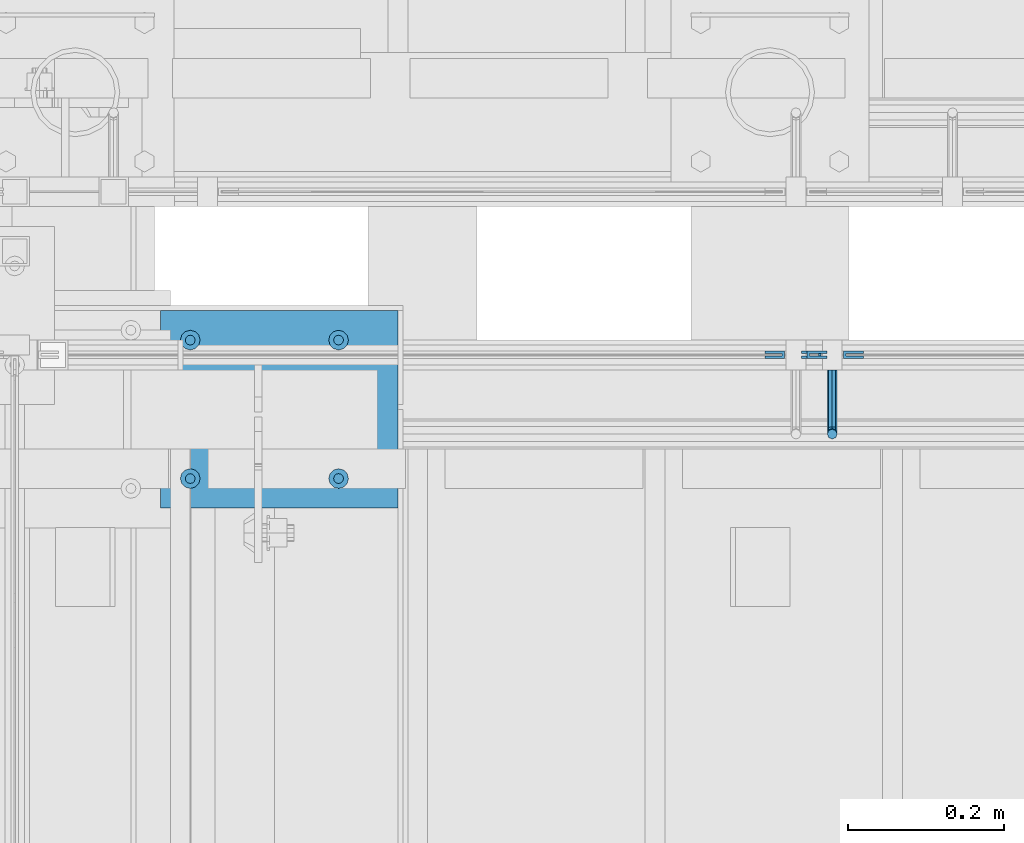
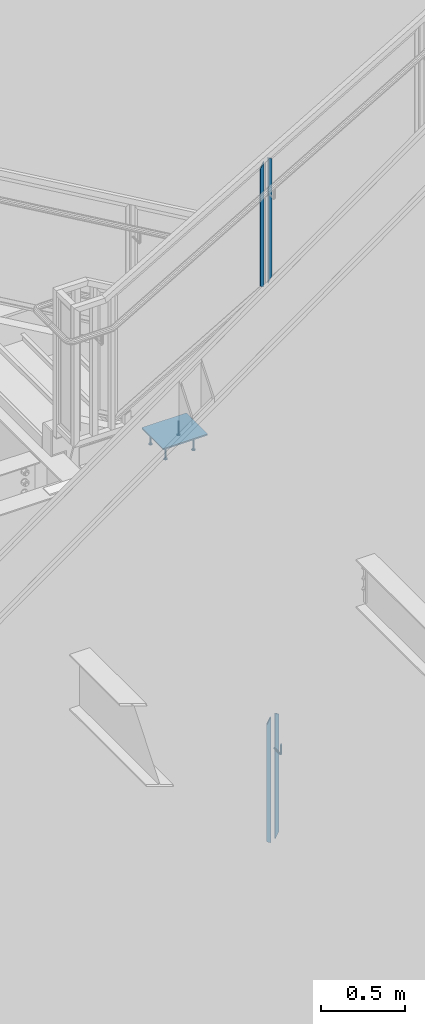
# One storey, part 912 of 1179: 10 beams, 3 elements without a shape of their own.
"""IFC2X3 building model written with IfcOpenShell, lengths in millimetres."""

from ifc_helpers import new_model, si_unit, frame, origin_with_axes, place, context, subcontext, project, spatial, faceted_brep, material, type_object, element, aggregate, save


model = new_model("IFC2X3")

# Units and contexts
model_context = context("Model", 3, precision=1e-05, world=origin_with_axes())
body_context = subcontext(model_context, "Body", "Model", "MODEL_VIEW")
ifc_project = project(units=[si_unit("LENGTHUNIT", "METRE", prefix="MILLI"), si_unit("AREAUNIT", "SQUARE_METRE"), si_unit("VOLUMEUNIT", "CUBIC_METRE"), si_unit("MASSUNIT", "GRAM", prefix="KILO"), si_unit("TIMEUNIT", "SECOND"), si_unit("PLANEANGLEUNIT", "RADIAN"), si_unit("SOLIDANGLEUNIT", "STERADIAN"), si_unit("THERMODYNAMICTEMPERATUREUNIT", "DEGREE_CELSIUS"), si_unit("LUMINOUSINTENSITYUNIT", "LUMEN")], contexts=[model_context])

# Site, building, storey
site_placement = place(None, origin_with_axes())
site = spatial("IfcSite", under=ifc_project, at=site_placement, CompositionType="ELEMENT")
building_placement = place(site_placement, origin_with_axes())
building = spatial("IfcBuilding", under=site, at=building_placement, Name="Undefined", CompositionType="ELEMENT")
storey_placement = place(building_placement, origin_with_axes())
storey = spatial("IfcBuildingStorey", under=building, at=storey_placement, Name="Undefined", CompositionType="ELEMENT", Elevation=0.0)

# Assembly, beams
assembly_1_placement = place(storey_placement, origin_with_axes())
assembly_1 = element("IfcElementAssembly", 1, at=assembly_1_placement, inside=storey, Name="GUARDRAIL", AssemblyPlace="NOTDEFINED", PredefinedType="RIGID_FRAME")
ifc_material_1 = material(Name="STEEL/BUY-OUT")
beam_type_1 = type_object("IfcBeamType", PredefinedType="NOTDEFINED")
beam_1_placement = place(assembly_1_placement, frame((20648.5331516659, 39468.4251646336, 5478.99797595162), z_axis=(0.0, 0.0, -1.0), x_axis=(-1.0, 0.0, 0.0)))
beam_1 = element("IfcBeam", 2, at=beam_1_placement, type_object=beam_type_1, material=ifc_material_1, Name="U-EDGE", context=body_context, shape_type="Brep", body=[
    faceted_brep([(0.0, 1.58750000000146, -439.43612632327), (0.0, -1.58750000000146, -439.43612632327), (0.0, -1.58750000000146, 409.802710675423), (0.0, 1.58750000000146, 409.802710675423), (22.2250000000313, 1.58750000000146, -452.201447879431), (22.2250000000313, 1.58750000000146, 448.497212762225), (22.2250000000313, 4.76249999999709, -452.201447879431), (22.2250000000313, 4.76249999999709, 448.497212762225), (6.54836185276508e-11, 4.76249999999709, -439.436126323308), (6.54836185276508e-11, 4.76249999999709, 409.802710675536), (6.54836185276508e-11, 7.9375, -439.436126323308), (6.54836185276508e-11, 7.9375, 409.802710675536), (25.4000000000342, 7.9375, -454.025), (25.4000000000342, 7.9375, 454.025), (25.4000000000342, -1.58750000000146, -454.025), (25.4000000000342, -1.58750000000146, 454.025)], [[[0, 1, 2, 3]], [[4, 0, 3, 5]], [[6, 4, 5, 7]], [[8, 6, 7, 9]], [[10, 8, 9, 11]], [[12, 10, 11, 13]], [[14, 12, 13, 15]], [[11, 9, 7, 5, 3, 2, 15, 13]], [[1, 14, 15, 2]], [[0, 4, 6, 8, 10, 12, 14, 1]]]),
])
beam_2_placement = place(assembly_1_placement, frame((20568.894845367, 39468.4251646336, 5462.17576533942), z_axis=(0.0, 0.0, -1.0), x_axis=(1.0, 0.0, 0.0)))
beam_2 = element("IfcBeam", 3, at=beam_2_placement, type_object=beam_type_1, material=ifc_material_1, Name="U-EDGE", context=body_context, shape_type="Brep", body=[
    faceted_brep([(6.54836185276508e-11, -4.76249999999709, -409.802660159926), (6.54836185276508e-11, -7.9375, -409.802660159925), (6.54836185276508e-11, -7.9375, 439.435789033928), (6.54836185276508e-11, -4.76249999999709, 439.435789033928), (22.2250000000313, -4.76249999999709, -448.497207519993), (22.2250000000313, -4.76249999999709, 452.20157845494), (22.2250000000313, -1.58750000000146, -448.497207519993), (22.2250000000313, -1.58750000000146, 452.20157845494), (0.0, -1.58750000000146, -409.802660159811), (0.0, -1.58750000000146, 439.43578903389), (0.0, 1.58750000000146, -409.802660159811), (0.0, 1.58750000000146, 439.43578903389), (25.4000000000342, 1.58750000000146, -454.025), (25.4000000000342, 1.58750000000146, 454.025), (25.4000000000342, -7.9375, -454.025), (25.4000000000342, -7.9375, 454.025)], [[[0, 1, 2, 3]], [[4, 0, 3, 5]], [[6, 4, 5, 7]], [[8, 6, 7, 9]], [[10, 8, 9, 11]], [[12, 10, 11, 13]], [[14, 12, 13, 15]], [[11, 9, 7, 5, 3, 2, 15, 13]], [[1, 14, 15, 2]], [[0, 4, 6, 8, 10, 12, 14, 1]]]),
])
aggregate(assembly_1, [beam_1, beam_2])

assembly_2_placement = place(storey_placement, origin_with_axes())
assembly_2 = element("IfcElementAssembly", 4, at=assembly_2_placement, inside=storey, Name="GUARDRAIL", AssemblyPlace="NOTDEFINED", PredefinedType="RIGID_FRAME")
beam_3_placement = place(assembly_2_placement, frame((20695.5760047361, 39468.4251653905, 1442.24748915281), z_axis=(0.0, 0.0, -1.0), x_axis=(-1.0, 0.0, 0.0)))
beam_3 = element("IfcBeam", 5, at=beam_3_placement, type_object=beam_type_1, material=ifc_material_1, Name="U-EDGE", context=body_context, shape_type="Brep", body=[
    faceted_brep([(0.0, 1.58750000000146, -439.570271458992), (0.0, -1.58750000000146, -439.570271458992), (0.0, -1.58750000000146, 410.762302941614), (0.0, 1.58750000000146, 410.762302941614), (22.2250000000131, 1.58750000000146, -452.383647202629), (22.2250000000131, 1.58750000000146, 449.311912848919), (22.2250000000131, 4.76249999999709, -452.383647202629), (22.2250000000131, 4.76249999999709, 449.311912848919), (2.91038304567337e-11, 4.76249999999709, -439.570271459009), (2.91038304567337e-11, 4.76249999999709, 410.762303199042), (2.91038304567337e-11, 7.9375, -439.570271459009), (2.91038304567337e-11, 7.9375, 410.762303199042), (25.400000000016, 7.9375, -454.214129451719), (25.3999999999687, 7.9375, 454.819), (25.400000000016, -1.58750000000146, -454.214129451719), (25.3999999999687, -1.58750000000146, 454.819)], [[[0, 1, 2, 3]], [[4, 0, 3, 5]], [[6, 4, 5, 7]], [[8, 6, 7, 9]], [[10, 8, 9, 11]], [[12, 10, 11, 13]], [[14, 12, 13, 15]], [[11, 9, 7, 5, 3, 2, 15, 13]], [[1, 14, 15, 2]], [[0, 4, 6, 8, 10, 12, 14, 1]]]),
])
beam_4_placement = place(assembly_2_placement, frame((20615.8041297361, 39468.4251653905, 1425.47281842366), z_axis=(0.0, 0.0, -1.0), x_axis=(1.0, 0.0, 0.0)))
beam_4 = element("IfcBeam", 6, at=beam_4_placement, type_object=beam_type_1, material=ifc_material_1, Name="U-EDGE", context=body_context, shape_type="Brep", body=[
    faceted_brep([(2.91038304567337e-11, -4.76249999999709, -410.157581087356), (2.91038304567337e-11, -7.9375, -410.157581087356), (2.91038304567337e-11, -7.9375, 440.175143067736), (2.91038304567337e-11, -4.76249999999709, 440.175143067736), (22.2250000000131, -4.76249999999709, -448.707195046795), (22.2250000000131, -4.76249999999709, 452.988518745257), (22.2250000000131, -1.58750000000146, -448.707195046795), (22.2250000000131, -1.58750000000146, 452.988518745257), (0.0, -1.58750000000146, -410.157581087306), (0.0, -1.58750000000146, 440.175143067719), (0.0, 1.58750000000146, -410.157581087305), (0.0, 1.58750000000146, 440.175143067719), (25.400000000016, 1.58750000000146, -454.21428275529), (25.400000000016, 1.58750000000146, 454.819), (25.400000000016, -7.9375, -454.21428275529), (25.400000000016, -7.9375, 454.819)], [[[0, 1, 2, 3]], [[4, 0, 3, 5]], [[6, 4, 5, 7]], [[8, 6, 7, 9]], [[10, 8, 9, 11]], [[12, 10, 11, 13]], [[14, 12, 13, 15]], [[11, 9, 7, 5, 3, 2, 15, 13]], [[1, 14, 15, 2]], [[0, 4, 6, 8, 10, 12, 14, 1]]]),
])
ifc_material_2 = material(Name="STEEL/A36")
beam_type_2 = type_object("IfcBeamType", PredefinedType="NOTDEFINED")
beam_5_placement = place(assembly_2_placement, frame((20655.4916297361, 39452.5499999814, 1661.1938590981), z_axis=(0.0, 0.0, 1.0), x_axis=(0.0, -1.0, 0.0)))
beam_5 = element("IfcBeam", 7, at=beam_5_placement, type_object=beam_type_2, material=ifc_material_2, Name="BRACKET", context=body_context, shape_type="Brep", body=[
    faceted_brep([(0.0, 0.0, 6.34999999999991), (0.0, -4.49012806053361, 4.49012806053452), (69.849999425729, -4.49012806053361, 4.49012806053452), (69.849999425729, 0.0, 6.34999999999991), (0.0, 4.49012806053361, 4.49012806053452), (69.849999425729, 4.49012806053361, 4.49012806053452), (0.0, 6.34999999999854, 0.0), (69.849999425729, 6.34999999999854, 0.0), (0.0, 4.49012806053361, -4.49012806053452), (69.849999425729, 4.49012806053361, -4.49012806053452), (0.0, 0.0, -6.34999999999991), (69.849999425729, 0.0, -6.34999999999991), (0.0, -4.49012806053361, -4.49012806053452), (69.849999425729, -4.49012806053361, -4.49012806053452), (0.0, -6.34999999999854, 0.0), (69.849999425729, -6.34999999999854, 0.0), (76.1999993303689, -6.34999999999854, 1.70147734638658), (73.9549353000984, -4.49012806053361, 5.59004231305425), (73.024999330366, 0.0, 7.20073866041639), (73.9549353000984, 4.49012806053361, 5.59004231305425), (76.1999993303689, 6.34999999999854, 1.70147734638658), (78.445063360632, 4.49012806053361, -2.18708762028064), (79.3749993303718, 0.0, -3.79778396764323), (78.445063360632, -4.49012806053361, -2.18708762028064), (84.7370868552753, 4.49012806053361, 4.10493587436031), (87.0401272955278, 4.49012806053361, 12.6999998092651), (88.8999992349927, 0.0, 12.6999998092651), (86.3477832026401, 0.0, 3.17499990462693), (80.8485218886053, 6.34999999999854, 6.34999990462893), (82.5499992349942, 6.34999999999854, 12.6999998092651), (76.9599569219426, 4.49012806053361, 8.59506393489755), (78.0598711744606, 4.49012806053361, 12.6999998092651), (75.3492605745778, 0.0, 9.52499990463093), (76.1999992349956, 0.0, 12.6999998092651), (76.9599569219426, -4.49012806053361, 8.59506393489755), (78.0598711744606, -4.49012806053361, 12.6999998092651), (80.8485218886053, -6.34999999999854, 6.34999990462893), (82.5499992349942, -6.34999999999854, 12.6999998092651), (84.7370868552753, -4.49012806053361, 4.10493587436031), (87.0401272955278, -4.49012806053361, 12.6999998092651), (88.8999992349927, 0.0, 76.2000000000003), (87.0401280961523, -4.4901280621234, 73.5807586148453), (82.5500000355751, -6.35000000147556, 72.4958333104305), (78.0598719750778, -4.4901280619415, 73.5807586149517), (76.1999992349956, 0.0, 76.2000000000003), (78.0598719752597, 4.49012805902021, 78.8192413833694), (82.550000035837, 6.34999999837237, 79.9041666931562), (87.0401280963342, 4.49012805883831, 78.819241383263)], [[[0, 1, 2, 3]], [[4, 0, 3, 5]], [[6, 4, 5, 7]], [[8, 6, 7, 9]], [[10, 8, 9, 11]], [[12, 10, 11, 13]], [[1, 0, 4, 6, 8, 10, 12, 14]], [[1, 14, 15, 2]], [[14, 12, 13, 15]], [[2, 15, 16, 17]], [[3, 2, 17, 18]], [[5, 3, 18, 19]], [[7, 5, 19, 20]], [[9, 7, 20, 21]], [[11, 9, 21, 22]], [[13, 11, 22, 23]], [[24, 25, 26, 27]], [[28, 29, 25, 24]], [[30, 31, 29, 28]], [[32, 33, 31, 30]], [[34, 35, 33, 32]], [[36, 37, 35, 34]], [[38, 39, 37, 36]], [[27, 26, 39, 38]], [[22, 27, 38, 23]], [[21, 24, 27, 22]], [[20, 28, 24, 21]], [[19, 30, 28, 20]], [[18, 32, 30, 19]], [[17, 34, 32, 18]], [[16, 36, 34, 17]], [[23, 38, 36, 16]], [[15, 13, 23, 16]], [[39, 26, 40, 41]], [[37, 39, 41, 42]], [[35, 37, 42, 43]], [[33, 35, 43, 44]], [[31, 33, 44, 45]], [[29, 31, 45, 46]], [[25, 29, 46, 47]], [[26, 25, 47, 40]], [[46, 45, 44, 43, 42, 41, 40, 47]]]),
])
aggregate(assembly_2, [beam_5, beam_3, beam_4])

assembly_3_placement = place(storey_placement, origin_with_axes())
assembly_3 = element("IfcElementAssembly", 8, at=assembly_3_placement, inside=storey, Name="EMBED", AssemblyPlace="NOTDEFINED", PredefinedType="RIGID_FRAME")
ifc_material_3 = material(Name="STEEL/A108")
beam_type_3 = type_object("IfcBeamType", Name="STUD_1/2-DIA", PredefinedType="NOTDEFINED")
beam_6_placement = place(assembly_3_placement, frame((20021.55, 39312.8499999899, 4225.925), z_axis=(0.0, -1.0, 0.0), x_axis=(0.0, 0.0, -1.0)))
beam_6 = element("IfcBeam", 9, at=beam_6_placement, type_object=beam_type_3, material=ifc_material_3, Name="SHEAR STUD", ObjectType="STUD_1/2-DIA", context=body_context, shape_type="Brep", body=[
    faceted_brep([(0.0, -3.1800000667572, 5.5), (0.0, -5.5, 3.1800000667572), (94.4880000000003, -5.5, 3.1800000667572), (94.4880000000003, -3.1800000667572, 5.5), (0.0, -6.34999999999854, 0.0), (94.4880000000003, -6.34999990463257, 0.0), (0.0, -5.5, -3.1800000667572), (94.4880000000003, -5.5, -3.1800000667572), (0.0, -3.1800000667572, -5.5), (94.4880000000003, -3.1800000667572, -5.5), (0.0, 0.0, -6.34999999999991), (94.4880000000003, 0.0, -6.34999990463257), (0.0, 3.1800000667572, -5.5), (94.4880000000003, 3.1800000667572, -5.5), (0.0, 5.5, -3.1800000667572), (94.4880000000003, 5.5, -3.1800000667572), (0.0, 6.34999999999854, 0.0), (94.4880000000003, 6.34999990463257, 0.0), (0.0, 5.5, 3.1800000667572), (94.4880000000003, 5.5, 3.1800000667572), (0.0, 3.1800000667572, 5.5), (94.4880000000003, 3.1800000667572, 5.5), (0.0, 0.0, 6.34999999999991), (94.4880000000003, 0.0, 6.34999990463257), (96.5200000000004, -10.9899997711182, 6.34999990463257), (96.5200000000004, -6.34000015258789, 10.9899997711182), (96.5200000000004, -12.6999998092651, 0.0), (96.5200000000004, -10.9899997711182, -6.34999990463257), (96.5200000000004, -6.34000015258789, -10.9899997711182), (96.5200000000004, 0.0, -12.6899995803833), (96.5200000000004, 6.34000015258789, -10.9899997711182), (96.5200000000004, 10.9899997711182, -6.34999990463257), (96.5200000000004, 12.6999998092651, 0.0), (96.5200000000004, 10.9899997711182, 6.34999990463257), (96.5200000000004, 6.34000015258789, 10.9899997711182), (96.5200000000004, 0.0, 12.6899995803833), (101.6, -10.9899997711182, 6.34999990463257), (101.6, -6.34000015258789, 10.9899997711182), (101.6, -12.6999998092651, 0.0), (101.6, -10.9899997711182, -6.34999990463257), (101.6, -6.34000015258789, -10.9899997711182), (101.6, 0.0, -12.6899995803833), (101.6, 6.34000015258789, -10.9899997711182), (101.6, 10.9899997711182, -6.34999990463257), (101.6, 12.6999998092651, 0.0), (101.6, 10.9899997711182, 6.34999990463257), (101.6, 6.34000015258789, 10.9899997711182), (101.6, 0.0, 12.6899995803833)], [[[0, 1, 2, 3]], [[1, 4, 5, 2]], [[4, 6, 7, 5]], [[6, 8, 9, 7]], [[8, 10, 11, 9]], [[10, 12, 13, 11]], [[12, 14, 15, 13]], [[14, 16, 17, 15]], [[16, 18, 19, 17]], [[18, 20, 21, 19]], [[20, 22, 23, 21]], [[22, 0, 3, 23]], [[22, 20, 18, 16, 14, 12, 10, 8, 6, 4, 1, 0]], [[3, 2, 24, 25]], [[2, 5, 26, 24]], [[5, 7, 27, 26]], [[7, 9, 28, 27]], [[9, 11, 29, 28]], [[11, 13, 30, 29]], [[13, 15, 31, 30]], [[15, 17, 32, 31]], [[17, 19, 33, 32]], [[19, 21, 34, 33]], [[21, 23, 35, 34]], [[23, 3, 25, 35]], [[25, 24, 36, 37]], [[24, 26, 38, 36]], [[26, 27, 39, 38]], [[27, 28, 40, 39]], [[28, 29, 41, 40]], [[29, 30, 42, 41]], [[30, 31, 43, 42]], [[31, 32, 44, 43]], [[32, 33, 45, 44]], [[33, 34, 46, 45]], [[34, 35, 47, 46]], [[35, 25, 37, 47]], [[38, 39, 40, 41, 42, 43, 44, 45, 46, 47, 37, 36]]]),
])
beam_7_placement = place(assembly_3_placement, frame((19831.05, 39312.8499999899, 4225.925), z_axis=(0.0, -1.0, 0.0), x_axis=(0.0, 0.0, -1.0)))
beam_7 = element("IfcBeam", 10, at=beam_7_placement, type_object=beam_type_3, material=ifc_material_3, Name="SHEAR STUD", ObjectType="STUD_1/2-DIA", context=body_context, shape_type="Brep", body=[
    faceted_brep([(0.0, -3.1800000667572, 5.5), (0.0, -5.5, 3.1800000667572), (94.4880000000003, -5.5, 3.1800000667572), (94.4880000000003, -3.1800000667572, 5.5), (0.0, -6.34999999999854, 0.0), (94.4880000000003, -6.34999990463257, 0.0), (0.0, -5.5, -3.1800000667572), (94.4880000000003, -5.5, -3.1800000667572), (0.0, -3.1800000667572, -5.5), (94.4880000000003, -3.1800000667572, -5.5), (0.0, 0.0, -6.34999999999991), (94.4880000000003, 0.0, -6.34999990463257), (0.0, 3.1800000667572, -5.5), (94.4880000000003, 3.1800000667572, -5.5), (0.0, 5.5, -3.1800000667572), (94.4880000000003, 5.5, -3.1800000667572), (0.0, 6.34999999999854, 0.0), (94.4880000000003, 6.34999990463257, 0.0), (0.0, 5.5, 3.1800000667572), (94.4880000000003, 5.5, 3.1800000667572), (0.0, 3.1800000667572, 5.5), (94.4880000000003, 3.1800000667572, 5.5), (0.0, 0.0, 6.34999999999991), (94.4880000000003, 0.0, 6.34999990463257), (96.5200000000004, -10.9899997711182, 6.34999990463257), (96.5200000000004, -6.34000015258789, 10.9899997711182), (96.5200000000004, -12.6999998092651, 0.0), (96.5200000000004, -10.9899997711182, -6.34999990463257), (96.5200000000004, -6.34000015258789, -10.9899997711182), (96.5200000000004, 0.0, -12.6899995803833), (96.5200000000004, 6.34000015258789, -10.9899997711182), (96.5200000000004, 10.9899997711182, -6.34999990463257), (96.5200000000004, 12.6999998092651, 0.0), (96.5200000000004, 10.9899997711182, 6.34999990463257), (96.5200000000004, 6.34000015258789, 10.9899997711182), (96.5200000000004, 0.0, 12.6899995803833), (101.6, -10.9899997711182, 6.34999990463257), (101.6, -6.34000015258789, 10.9899997711182), (101.6, -12.6999998092651, 0.0), (101.6, -10.9899997711182, -6.34999990463257), (101.6, -6.34000015258789, -10.9899997711182), (101.6, 0.0, -12.6899995803833), (101.6, 6.34000015258789, -10.9899997711182), (101.6, 10.9899997711182, -6.34999990463257), (101.6, 12.6999998092651, 0.0), (101.6, 10.9899997711182, 6.34999990463257), (101.6, 6.34000015258789, 10.9899997711182), (101.6, 0.0, 12.6899995803833)], [[[0, 1, 2, 3]], [[1, 4, 5, 2]], [[4, 6, 7, 5]], [[6, 8, 9, 7]], [[8, 10, 11, 9]], [[10, 12, 13, 11]], [[12, 14, 15, 13]], [[14, 16, 17, 15]], [[16, 18, 19, 17]], [[18, 20, 21, 19]], [[20, 22, 23, 21]], [[22, 0, 3, 23]], [[22, 20, 18, 16, 14, 12, 10, 8, 6, 4, 1, 0]], [[3, 2, 24, 25]], [[2, 5, 26, 24]], [[5, 7, 27, 26]], [[7, 9, 28, 27]], [[9, 11, 29, 28]], [[11, 13, 30, 29]], [[13, 15, 31, 30]], [[15, 17, 32, 31]], [[17, 19, 33, 32]], [[19, 21, 34, 33]], [[21, 23, 35, 34]], [[23, 3, 25, 35]], [[25, 24, 36, 37]], [[24, 26, 38, 36]], [[26, 27, 39, 38]], [[27, 28, 40, 39]], [[28, 29, 41, 40]], [[29, 30, 42, 41]], [[30, 31, 43, 42]], [[31, 32, 44, 43]], [[32, 33, 45, 44]], [[33, 34, 46, 45]], [[34, 35, 47, 46]], [[35, 25, 37, 47]], [[38, 39, 40, 41, 42, 43, 44, 45, 46, 47, 37, 36]]]),
])
beam_8_placement = place(assembly_3_placement, frame((20021.55, 39490.6499999899, 4225.925), z_axis=(0.0, -1.0, 0.0), x_axis=(0.0, 0.0, -1.0)))
beam_8 = element("IfcBeam", 11, at=beam_8_placement, type_object=beam_type_3, material=ifc_material_3, Name="SHEAR STUD", ObjectType="STUD_1/2-DIA", context=body_context, shape_type="Brep", body=[
    faceted_brep([(0.0, -3.1800000667572, 5.5), (0.0, -5.5, 3.1800000667572), (94.4880000000003, -5.5, 3.1800000667572), (94.4880000000003, -3.1800000667572, 5.5), (0.0, -6.34999999999854, 0.0), (94.4880000000003, -6.34999990463257, 0.0), (0.0, -5.5, -3.1800000667572), (94.4880000000003, -5.5, -3.1800000667572), (0.0, -3.1800000667572, -5.5), (94.4880000000003, -3.1800000667572, -5.5), (0.0, 0.0, -6.34999999999991), (94.4880000000003, 0.0, -6.34999990463257), (0.0, 3.1800000667572, -5.5), (94.4880000000003, 3.1800000667572, -5.5), (0.0, 5.5, -3.1800000667572), (94.4880000000003, 5.5, -3.1800000667572), (0.0, 6.34999999999854, 0.0), (94.4880000000003, 6.34999990463257, 0.0), (0.0, 5.5, 3.1800000667572), (94.4880000000003, 5.5, 3.1800000667572), (0.0, 3.1800000667572, 5.5), (94.4880000000003, 3.1800000667572, 5.5), (0.0, 0.0, 6.34999999999991), (94.4880000000003, 0.0, 6.34999990463257), (96.5200000000004, -10.9899997711182, 6.34999990463257), (96.5200000000004, -6.34000015258789, 10.9899997711182), (96.5200000000004, -12.6999998092651, 0.0), (96.5200000000004, -10.9899997711182, -6.34999990463257), (96.5200000000004, -6.34000015258789, -10.9899997711182), (96.5200000000004, 0.0, -12.6899995803833), (96.5200000000004, 6.34000015258789, -10.9899997711182), (96.5200000000004, 10.9899997711182, -6.34999990463257), (96.5200000000004, 12.6999998092651, 0.0), (96.5200000000004, 10.9899997711182, 6.34999990463257), (96.5200000000004, 6.34000015258789, 10.9899997711182), (96.5200000000004, 0.0, 12.6899995803833), (101.6, -10.9899997711182, 6.34999990463257), (101.6, -6.34000015258789, 10.9899997711182), (101.6, -12.6999998092651, 0.0), (101.6, -10.9899997711182, -6.34999990463257), (101.6, -6.34000015258789, -10.9899997711182), (101.6, 0.0, -12.6899995803833), (101.6, 6.34000015258789, -10.9899997711182), (101.6, 10.9899997711182, -6.34999990463257), (101.6, 12.6999998092651, 0.0), (101.6, 10.9899997711182, 6.34999990463257), (101.6, 6.34000015258789, 10.9899997711182), (101.6, 0.0, 12.6899995803833)], [[[0, 1, 2, 3]], [[1, 4, 5, 2]], [[4, 6, 7, 5]], [[6, 8, 9, 7]], [[8, 10, 11, 9]], [[10, 12, 13, 11]], [[12, 14, 15, 13]], [[14, 16, 17, 15]], [[16, 18, 19, 17]], [[18, 20, 21, 19]], [[20, 22, 23, 21]], [[22, 0, 3, 23]], [[22, 20, 18, 16, 14, 12, 10, 8, 6, 4, 1, 0]], [[3, 2, 24, 25]], [[2, 5, 26, 24]], [[5, 7, 27, 26]], [[7, 9, 28, 27]], [[9, 11, 29, 28]], [[11, 13, 30, 29]], [[13, 15, 31, 30]], [[15, 17, 32, 31]], [[17, 19, 33, 32]], [[19, 21, 34, 33]], [[21, 23, 35, 34]], [[23, 3, 25, 35]], [[25, 24, 36, 37]], [[24, 26, 38, 36]], [[26, 27, 39, 38]], [[27, 28, 40, 39]], [[28, 29, 41, 40]], [[29, 30, 42, 41]], [[30, 31, 43, 42]], [[31, 32, 44, 43]], [[32, 33, 45, 44]], [[33, 34, 46, 45]], [[34, 35, 47, 46]], [[35, 25, 37, 47]], [[38, 39, 40, 41, 42, 43, 44, 45, 46, 47, 37, 36]]]),
])
beam_9_placement = place(assembly_3_placement, frame((19831.05, 39490.6499999899, 4225.925), z_axis=(0.0, -1.0, 0.0), x_axis=(0.0, 0.0, -1.0)))
beam_9 = element("IfcBeam", 12, at=beam_9_placement, type_object=beam_type_3, material=ifc_material_3, Name="SHEAR STUD", ObjectType="STUD_1/2-DIA", context=body_context, shape_type="Brep", body=[
    faceted_brep([(0.0, -3.1800000667572, 5.5), (0.0, -5.5, 3.1800000667572), (94.4880000000003, -5.5, 3.1800000667572), (94.4880000000003, -3.1800000667572, 5.5), (0.0, -6.34999999999854, 0.0), (94.4880000000003, -6.34999990463257, 0.0), (0.0, -5.5, -3.1800000667572), (94.4880000000003, -5.5, -3.1800000667572), (0.0, -3.1800000667572, -5.5), (94.4880000000003, -3.1800000667572, -5.5), (0.0, 0.0, -6.34999999999991), (94.4880000000003, 0.0, -6.34999990463257), (0.0, 3.1800000667572, -5.5), (94.4880000000003, 3.1800000667572, -5.5), (0.0, 5.5, -3.1800000667572), (94.4880000000003, 5.5, -3.1800000667572), (0.0, 6.34999999999854, 0.0), (94.4880000000003, 6.34999990463257, 0.0), (0.0, 5.5, 3.1800000667572), (94.4880000000003, 5.5, 3.1800000667572), (0.0, 3.1800000667572, 5.5), (94.4880000000003, 3.1800000667572, 5.5), (0.0, 0.0, 6.34999999999991), (94.4880000000003, 0.0, 6.34999990463257), (96.5200000000004, -10.9899997711182, 6.34999990463257), (96.5200000000004, -6.34000015258789, 10.9899997711182), (96.5200000000004, -12.6999998092651, 0.0), (96.5200000000004, -10.9899997711182, -6.34999990463257), (96.5200000000004, -6.34000015258789, -10.9899997711182), (96.5200000000004, 0.0, -12.6899995803833), (96.5200000000004, 6.34000015258789, -10.9899997711182), (96.5200000000004, 10.9899997711182, -6.34999990463257), (96.5200000000004, 12.6999998092651, 0.0), (96.5200000000004, 10.9899997711182, 6.34999990463257), (96.5200000000004, 6.34000015258789, 10.9899997711182), (96.5200000000004, 0.0, 12.6899995803833), (101.6, -10.9899997711182, 6.34999990463257), (101.6, -6.34000015258789, 10.9899997711182), (101.6, -12.6999998092651, 0.0), (101.6, -10.9899997711182, -6.34999990463257), (101.6, -6.34000015258789, -10.9899997711182), (101.6, 0.0, -12.6899995803833), (101.6, 6.34000015258789, -10.9899997711182), (101.6, 10.9899997711182, -6.34999990463257), (101.6, 12.6999998092651, 0.0), (101.6, 10.9899997711182, 6.34999990463257), (101.6, 6.34000015258789, 10.9899997711182), (101.6, 0.0, 12.6899995803833)], [[[0, 1, 2, 3]], [[1, 4, 5, 2]], [[4, 6, 7, 5]], [[6, 8, 9, 7]], [[8, 10, 11, 9]], [[10, 12, 13, 11]], [[12, 14, 15, 13]], [[14, 16, 17, 15]], [[16, 18, 19, 17]], [[18, 20, 21, 19]], [[20, 22, 23, 21]], [[22, 0, 3, 23]], [[22, 20, 18, 16, 14, 12, 10, 8, 6, 4, 1, 0]], [[3, 2, 24, 25]], [[2, 5, 26, 24]], [[5, 7, 27, 26]], [[7, 9, 28, 27]], [[9, 11, 29, 28]], [[11, 13, 30, 29]], [[13, 15, 31, 30]], [[15, 17, 32, 31]], [[17, 19, 33, 32]], [[19, 21, 34, 33]], [[21, 23, 35, 34]], [[23, 3, 25, 35]], [[25, 24, 36, 37]], [[24, 26, 38, 36]], [[26, 27, 39, 38]], [[27, 28, 40, 39]], [[28, 29, 41, 40]], [[29, 30, 42, 41]], [[30, 31, 43, 42]], [[31, 32, 44, 43]], [[32, 33, 45, 44]], [[33, 34, 46, 45]], [[34, 35, 47, 46]], [[35, 25, 37, 47]], [[38, 39, 40, 41, 42, 43, 44, 45, 46, 47, 37, 36]]]),
])
beam_type_4 = type_object("IfcBeamType", PredefinedType="NOTDEFINED")
beam_10_placement = place(assembly_3_placement, frame((20097.75, 39401.7499999899, 4230.6875), z_axis=(0.0, 1.0, 0.0), x_axis=(-1.0, 0.0, 0.0)))
beam_10 = element("IfcBeam", 13, at=beam_10_placement, type_object=beam_type_4, material=ifc_material_2, Name="EMBED", context=body_context, shape_type="Brep", body=[
    faceted_brep([(0.0, 4.76249999999982, -127.0), (0.0, 4.76249999999709, 127.0), (304.799999999999, 4.76249999999982, 127.0), (304.799999999999, 4.76249999999982, -127.0), (0.0, -4.76249999999709, 127.0), (304.799999999999, -4.76249999999982, 127.0), (0.0, -4.76249999999982, -127.0), (304.799999999999, -4.76249999999982, -127.0)], [[[0, 1, 2, 3]], [[1, 4, 5, 2]], [[4, 6, 7, 5]], [[6, 0, 3, 7]], [[5, 7, 3, 2]], [[6, 4, 1, 0]]]),
])
aggregate(assembly_3, [beam_6, beam_7, beam_8, beam_9, beam_10])

save(model, "model.ifc")
